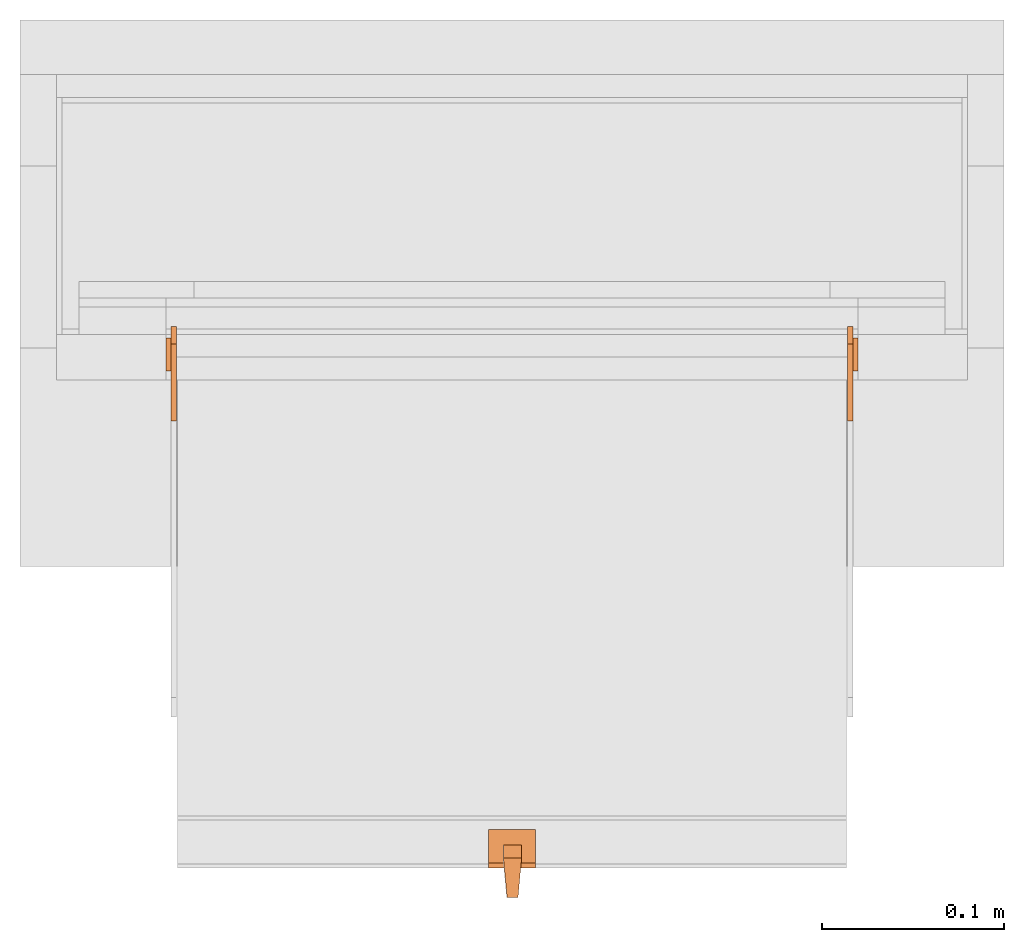
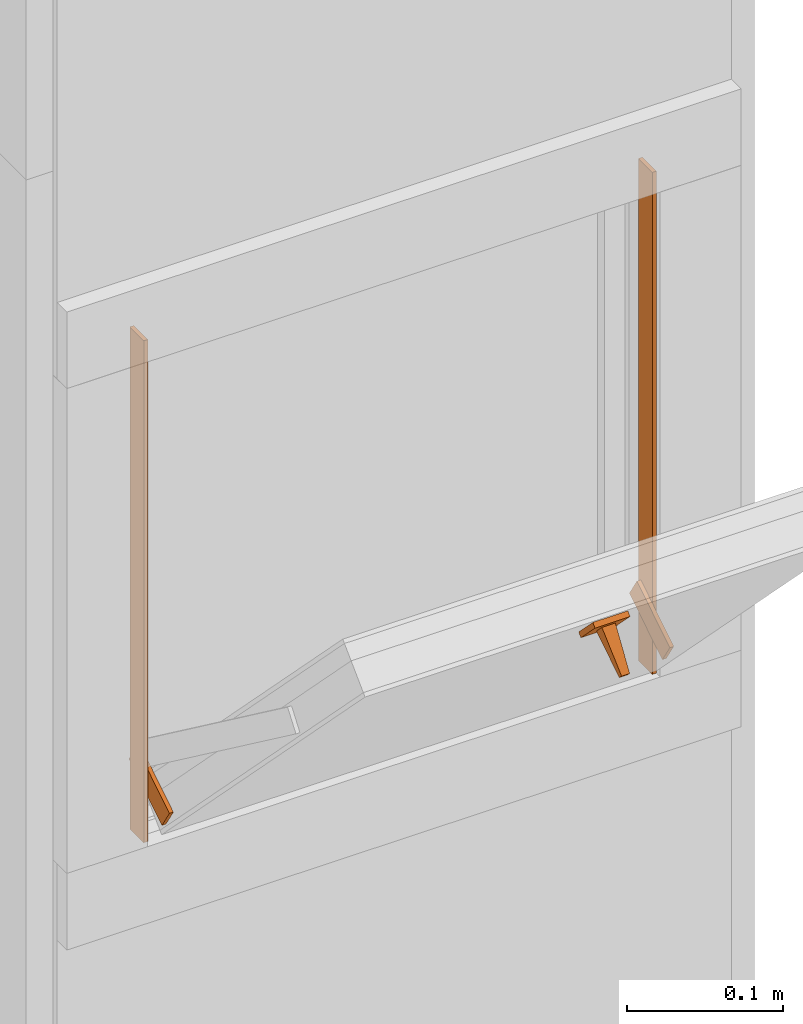
# One storey, part 2 of 3: 6 proxies.
"""IFC2X3 building model written with IfcOpenShell, lengths in metres."""

from ifc_helpers import new_model, entity, si_unit, converted_unit, derived_unit, money_unit, direction, frame, origin_with_axes, place, context, subcontext, project, spatial, polyline, outline, extrude, faceted_brep, source, transform, mapped, material, type_object, element, save


model = new_model("IFC2X3")

# Units and contexts
model_context = context("Model", 3, precision=1e-05, world=origin_with_axes(), true_north=direction((0.0, 1.0)))
plan_context = context("Plan", 3, precision=1e-05, world=origin_with_axes(), true_north=direction((0.0, 1.0)))
body_context = subcontext(model_context, "Body", "Model", "MODEL_VIEW")
ifc_project = project(units=[si_unit("LENGTHUNIT", "METRE"), si_unit("AREAUNIT", "SQUARE_METRE"), si_unit("VOLUMEUNIT", "CUBIC_METRE"), converted_unit("PLANEANGLEUNIT", "DEGREE", entity("IfcPlaneAngleMeasure", 0.0174532925199), si_unit("PLANEANGLEUNIT", "RADIAN"), dimensions=[0, 0, 0, 0, 0, 0, 0]), si_unit("SOLIDANGLEUNIT", "STERADIAN"), money_unit("CHF"), converted_unit("TIMEUNIT", "Year", entity("IfcTimeMeasure", 31556926.0), si_unit("TIMEUNIT", "SECOND"), dimensions=[0, 0, 1, 0, 0, 0, 0]), si_unit("MASSUNIT", "GRAM", prefix="KILO"), si_unit("THERMODYNAMICTEMPERATUREUNIT", "DEGREE_CELSIUS"), si_unit("LUMINOUSINTENSITYUNIT", "LUMEN"), si_unit("ENERGYUNIT", "JOULE", prefix="MEGA"), derived_unit("THERMALCONDUCTANCEUNIT", [(si_unit("POWERUNIT", "WATT"), 1), (si_unit("LENGTHUNIT", "METRE"), -1), (si_unit("THERMODYNAMICTEMPERATUREUNIT", "KELVIN"), -1)]), derived_unit("SPECIFICHEATCAPACITYUNIT", [(si_unit("ENERGYUNIT", "JOULE"), 1), (si_unit("MASSUNIT", "GRAM", prefix="KILO"), -1), (si_unit("THERMODYNAMICTEMPERATUREUNIT", "KELVIN"), -1)]), derived_unit("MASSDENSITYUNIT", [(si_unit("MASSUNIT", "GRAM", prefix="KILO"), 1), (si_unit("VOLUMEUNIT", "CUBIC_METRE"), -1)])], contexts=[model_context, plan_context])

# Site, building, storey
site_placement = place(None, origin_with_axes())
site = spatial("IfcSite", under=ifc_project, at=site_placement, CompositionType="ELEMENT")
building_placement = place(site_placement, origin_with_axes())
building = spatial("IfcBuilding", under=site, at=building_placement, CompositionType="ELEMENT")
storey_placement = place(building_placement, origin_with_axes())
storey = spatial("IfcBuildingStorey", under=building, at=storey_placement, Name="EG00", CompositionType="ELEMENT", Elevation=0.0)

# Proxies
ifc_material = material(Name="Metall, Aluminium")
building_element_proxy_type_1 = type_object("IfcBuildingElementProxyType", Name="Metall, Aluminium", PredefinedType="NOTDEFINED")
shared_shape_1 = source(origin_with_axes(), body_context, "Body", "Brep", [
    faceted_brep([(16.1345115895, -3.59726483298, 0.726478855326), (16.1345115895, -3.60026483298, 0.726478855326), (16.1345115895, -3.60026483298, 0.776478855326), (16.1345115895, -3.59726483298, 0.776478855326), (16.1525115895, -3.60026483298, 0.726478855326), (16.1525115895, -3.59726483298, 0.726478855326), (16.1525115895, -3.60026483298, 0.776478855326), (16.1525115895, -3.59726483298, 0.776478855326)], [[[0, 1, 2, 3]], [[4, 1, 0, 5]], [[1, 4, 6, 2]], [[2, 6, 7, 3]], [[0, 3, 7, 5]], [[4, 5, 7, 6]]]),
])
for number, where, z_axis, x_axis, name in (
    (1, (5.21982008204, -11.8786678245, 14.7145311427), (0.0, -0.846133712697, -0.532970674838), (0.0, 0.532970674838, -0.846133712697), "Wand-005"),
    (2, (5.59082008204, -11.8786678245, 14.7145311427), (0.0, -0.846133712697, -0.532970674838), (0.0, 0.532970674838, -0.846133712697), "Wand-005"),
):
    element("IfcBuildingElementProxy", number, at=place(storey_placement, frame(where, z_axis=z_axis, x_axis=x_axis)), inside=storey, type_object=building_element_proxy_type_1, material=ifc_material, Name=name, context=body_context, shape_type="MappedRepresentation", body=[
        mapped(shared_shape_1, transform((0.0, 0.0, 0.0))),
    ])
building_element_proxy_type_2 = type_object("IfcBuildingElementProxyType", Name="Metall, Aluminium 3", PredefinedType="NOTDEFINED")
proxy_1_placement = place(storey_placement, frame((1.99655524907, -3.89078861887, 0.61), z_axis=(0.0, 0.0, 1.0), x_axis=(0.0, -1.0, 0.0)))
element("IfcBuildingElementProxy", 3, at=proxy_1_placement, inside=storey, type_object=building_element_proxy_type_2, material=ifc_material, Name="Wand-006", context=body_context, shape_type="SweptSolid", body=[
    extrude(outline(polyline([(0.0, -0.003), (0.018, -0.003), (0.018, 0.0), (0.0, 0.0), (0.0, -0.003)])), origin_with_axes(), (0.0, 0.0, 1.0), 0.393521144674),
])
proxy_2_placement = place(storey_placement, frame((1.61655524907, -3.89078861887, 0.61), z_axis=(0.0, 0.0, 1.0), x_axis=(0.0, -1.0, 0.0)))
element("IfcBuildingElementProxy", 4, at=proxy_2_placement, inside=storey, type_object=building_element_proxy_type_2, material=ifc_material, Name="Wand-006", context=body_context, shape_type="SweptSolid", body=[
    extrude(outline(polyline([(0.0, 0.0), (0.018, 0.0), (0.018, 0.003), (0.0, 0.003), (0.0, 0.0)])), origin_with_axes(), (0.0, 0.0, 1.0), 0.393521144674),
])
shared_shape_2 = source(origin_with_axes(), body_context, "Body", "Brep", [
    faceted_brep([(16.3888858635, -3.43025891523, 1.114), (16.3888858635, -3.43025891523, 1.14), (16.3888858635, -3.40425891523, 1.14), (16.3888858635, -3.40425891523, 1.114), (16.3928858635, -3.43025891523, 1.114), (16.3928858635, -3.43025891523, 1.14), (16.3928858635, -3.40825891523, 1.14), (16.3928858635, -3.40425891523, 1.14), (16.3928858635, -3.40425891523, 1.114), (16.3928858635, -3.40825891523, 1.114)], [[[0, 1, 2, 3]], [[1, 0, 4]], [[2, 1, 5, 6, 7]], [[3, 2, 7, 8]], [[0, 3, 8, 9, 4]], [[1, 4, 5]], [[6, 5, 4]], [[6, 9, 8, 7]], [[9, 6, 4]]]),
])
proxy_3_placement = place(storey_placement, frame((5.2238141643, 8.31945325966, 11.5470677443), z_axis=(0.0, -0.700249431637, 0.713898265506), x_axis=(0.0, -0.713898265506, -0.700249431637)))
element("IfcBuildingElementProxy", 5, at=proxy_3_placement, inside=storey, type_object=building_element_proxy_type_1, material=ifc_material, Name="Wand-007", context=body_context, shape_type="MappedRepresentation", body=[
    mapped(shared_shape_2, transform((0.0, 0.0, 0.0))),
])
shared_shape_3 = source(origin_with_axes(), body_context, "Body", "Brep", [
    faceted_brep([(16.3891379247, -3.43334637562, 1.097), (16.3891379247, -3.44334637562, 1.097), (16.3921379247, -3.43534637562, 1.13058255688), (16.3991379247, -3.43334637562, 1.097), (16.3991379247, -3.44334637562, 1.097), (16.3921379247, -3.44134637562, 1.13058255688), (16.3961379247, -3.43523159518, 1.13058255688), (16.3961379247, -3.4414517679, 1.13058255688)], [[[0, 1, 2]], [[1, 0, 3, 4]], [[1, 5, 2]], [[0, 2, 3]], [[4, 3, 6]], [[5, 1, 4]], [[2, 5, 7]], [[3, 2, 6]], [[6, 7, 4]], [[7, 5, 4]], [[2, 7, 6]]]),
])
proxy_4_placement = place(storey_placement, frame((5.24519933596, -14.8694200011, 13.3444423362), z_axis=(0.0, -0.713898265506, -0.700249431636), x_axis=(0.0, 0.700249431636, -0.713898265506)))
element("IfcBuildingElementProxy", 6, at=proxy_4_placement, inside=storey, type_object=building_element_proxy_type_1, material=ifc_material, Name="Wand-008", context=body_context, shape_type="MappedRepresentation", body=[
    mapped(shared_shape_3, transform((0.0, 0.0, 0.0))),
])

save(model, "model.ifc")
